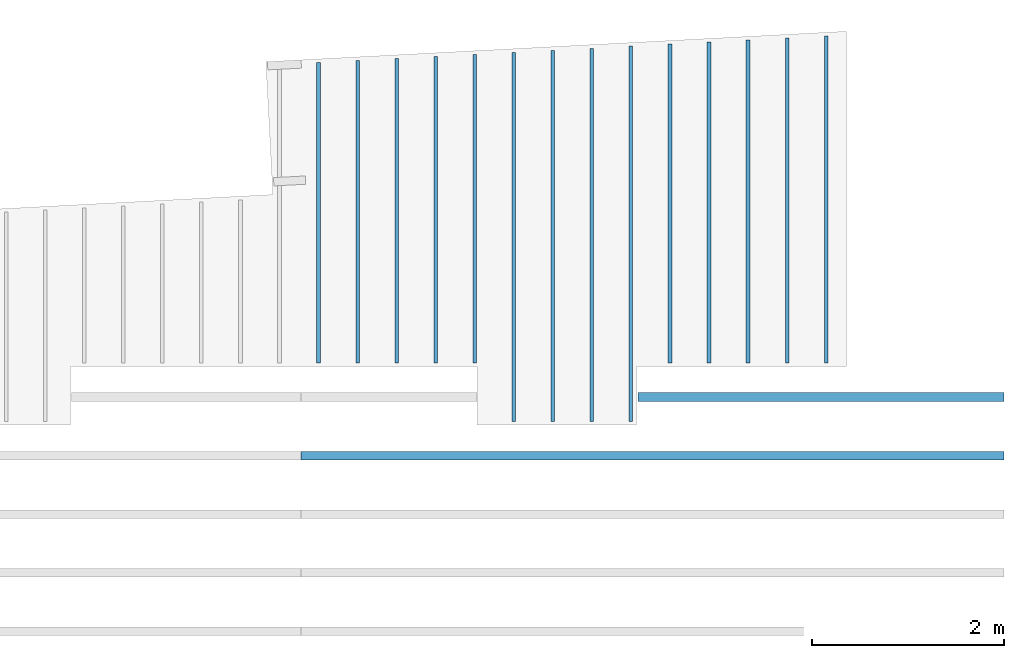
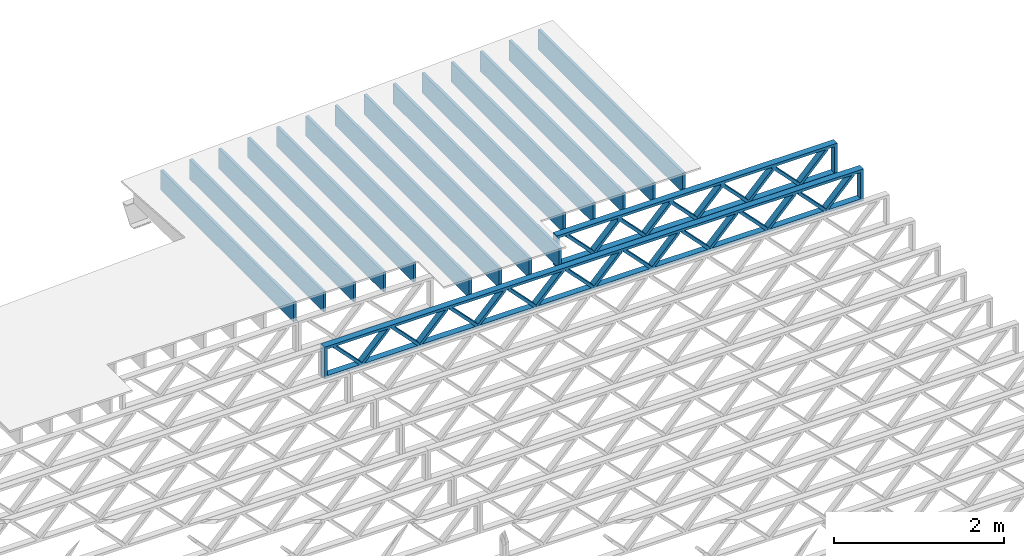
# One storey, part 12 of 13: 16 beams, 2 elements without a shape of their own.
"""IFC4 building model written with IfcOpenShell, lengths in feet."""

from ifc_helpers import new_model, entity, si_unit, converted_unit, derived_unit, direction, frame, frame_2d, origin, origin_2d_with_axis, place, context, subcontext, project, spatial, rectangle, extrude, source, transform, mapped, material, material_profile, profile_set, profile_usage, type_object, type_shapes, element, aggregate, save


model = new_model("IFC4")

# Units and contexts
model_context_1 = context("Model", 3, precision=0.0001, world=origin(), true_north=direction((6.12303176911189e-17, 1.0)))
model_context_2 = context("Model", 3, precision=0.0001, world=origin(), true_north=direction((6.12303176911189e-17, 1.0)))
body_context = subcontext(model_context_2, "Body", "Model", "MODEL_VIEW")
ifc_project = project(units=[converted_unit("LENGTHUNIT", "FOOT", entity("IfcRatioMeasure", 0.3048), si_unit("LENGTHUNIT", "METRE"), dimensions=[1, 0, 0, 0, 0, 0, 0]), converted_unit("AREAUNIT", "SQUARE FOOT", entity("IfcRatioMeasure", 0.09290304), si_unit("AREAUNIT", "SQUARE_METRE"), dimensions=[2, 0, 0, 0, 0, 0, 0]), converted_unit("VOLUMEUNIT", "CUBIC FOOT", entity("IfcRatioMeasure", 0.028316846592), si_unit("VOLUMEUNIT", "CUBIC_METRE"), dimensions=[3, 0, 0, 0, 0, 0, 0]), converted_unit("PLANEANGLEUNIT", "DEGREE", entity("IfcRatioMeasure", 0.0174532925199433), si_unit("PLANEANGLEUNIT", "RADIAN"), dimensions=[0, 0, 0, 0, 0, 0, 0]), si_unit("MASSUNIT", "GRAM", prefix="KILO"), derived_unit("MASSDENSITYUNIT", [(si_unit("MASSUNIT", "GRAM", prefix="KILO"), 1), (si_unit("LENGTHUNIT", "METRE"), -3)]), derived_unit("MOMENTOFINERTIAUNIT", [(si_unit("LENGTHUNIT", "METRE"), 4)]), si_unit("TIMEUNIT", "SECOND"), si_unit("FREQUENCYUNIT", "HERTZ"), si_unit("THERMODYNAMICTEMPERATUREUNIT", "DEGREE_CELSIUS"), derived_unit("THERMALTRANSMITTANCEUNIT", [(si_unit("MASSUNIT", "GRAM", prefix="KILO"), 1), (si_unit("THERMODYNAMICTEMPERATUREUNIT", "KELVIN"), -1), (si_unit("TIMEUNIT", "SECOND"), -3)]), derived_unit("VOLUMETRICFLOWRATEUNIT", [(si_unit("LENGTHUNIT", "METRE"), 3), (si_unit("TIMEUNIT", "SECOND"), -1)]), si_unit("ELECTRICCURRENTUNIT", "AMPERE"), si_unit("ELECTRICVOLTAGEUNIT", "VOLT"), si_unit("POWERUNIT", "WATT"), si_unit("FORCEUNIT", "NEWTON"), si_unit("ILLUMINANCEUNIT", "LUX"), si_unit("LUMINOUSFLUXUNIT", "LUMEN"), si_unit("LUMINOUSINTENSITYUNIT", "CANDELA"), derived_unit("USERDEFINED", [(si_unit("MASSUNIT", "GRAM", prefix="KILO"), -1), (si_unit("LENGTHUNIT", "METRE"), -2), (si_unit("TIMEUNIT", "SECOND"), 3), (si_unit("LUMINOUSFLUXUNIT", "LUMEN"), 1)]), derived_unit("LINEARVELOCITYUNIT", [(si_unit("LENGTHUNIT", "METRE"), 1), (si_unit("TIMEUNIT", "SECOND"), -1)]), si_unit("PRESSUREUNIT", "PASCAL"), derived_unit("USERDEFINED", [(si_unit("LENGTHUNIT", "METRE"), -2), (si_unit("MASSUNIT", "GRAM", prefix="KILO"), 1), (si_unit("TIMEUNIT", "SECOND"), -2)]), derived_unit("LINEARFORCEUNIT", [(si_unit("MASSUNIT", "GRAM", prefix="KILO"), 1), (si_unit("LENGTHUNIT", "METRE"), 1), (si_unit("TIMEUNIT", "SECOND"), -2), (si_unit("LENGTHUNIT", "METRE"), -1)]), derived_unit("PLANARFORCEUNIT", [(si_unit("MASSUNIT", "GRAM", prefix="KILO"), 1), (si_unit("LENGTHUNIT", "METRE"), 1), (si_unit("TIMEUNIT", "SECOND"), -2), (si_unit("LENGTHUNIT", "METRE"), -2)])], contexts=[model_context_1])

# Site, building, storey
site_placement = place(None, origin())
site = spatial("IfcSite", under=ifc_project, at=site_placement, CompositionType="ELEMENT")
building_placement = place(site_placement, origin())
building = spatial("IfcBuilding", under=site, at=building_placement, CompositionType="ELEMENT")
storey_placement = place(building_placement, frame((0.0, 0.0, 21.46875)))
storey = spatial("IfcBuildingStorey", under=building, at=storey_placement, Name="3RD FLOOR", CompositionType="ELEMENT", Elevation=21.46875)

# Assembly, beam
assembly_1_placement = place(storey_placement, origin())
assembly_1 = element("IfcElementAssembly", 1, at=assembly_1_placement, inside=storey, Name="Structural Beam System:Structural Framing System", ObjectType="Structural Beam System:Structural Framing System", AssemblyPlace="NOTDEFINED", PredefinedType="BEAM_GRID")
ifc_material_1 = material(Name="WOOD TRUSS", Category="Materials")
ifc_material_profile_1 = material_profile(ifc_material_1, rectangle(XDim=1.73473973950632, YDim=0.125, at=frame_2d((-1.11022302462516e-16, 8.32667268468867e-17), x_axis=(1.0, 0.0))))
ifc_material_profile_2 = material_profile(ifc_material_1, rectangle(XDim=1.73473973950633, YDim=0.125, at=frame_2d((-1.11022302462516e-16, 8.32667268468867e-17), x_axis=(1.0, 0.0))))
ifc_material_profile_3 = material_profile(ifc_material_1, rectangle(XDim=1.73473973950632, YDim=0.125, at=frame_2d((-5.55111512312578e-17, 1.38777878078145e-16), x_axis=(1.0, 0.0))))
ifc_material_profile_4 = material_profile(ifc_material_1, rectangle(XDim=1.73473973950633, YDim=0.125, at=frame_2d((-1.11022302462516e-16, 8.32667268468867e-17), x_axis=(1.0, 0.0))))
ifc_material_profile_5 = material_profile(ifc_material_1, rectangle(XDim=1.73473973950632, YDim=0.125, at=frame_2d((-1.11022302462516e-16, 8.32667268468867e-17), x_axis=(1.0, 0.0))))
ifc_material_profile_6 = material_profile(ifc_material_1, rectangle(XDim=1.73473973950633, YDim=0.125, at=frame_2d((-2.77555756156289e-16, 3.05311331771918e-16), x_axis=(1.0, 0.0))))
ifc_material_profile_7 = material_profile(ifc_material_1, rectangle(XDim=1.73473973950632, YDim=0.124999999999999, at=frame_2d((-3.88578058618805e-16, -2.4980018054066e-16), x_axis=(1.0, 0.0))))
ifc_material_profile_8 = material_profile(ifc_material_1, rectangle(XDim=1.73473973950633, YDim=0.125, at=frame_2d((2.77555756156289e-16, -3.05311331771918e-16), x_axis=(1.0, 0.0))))
ifc_material_profile_9 = material_profile(ifc_material_1, rectangle(XDim=1.73473973950632, YDim=0.124999999999999, at=frame_2d((-1.11022302462516e-16, 8.32667268468867e-17), x_axis=(1.0, 0.0))))
ifc_material_profile_10 = material_profile(ifc_material_1, rectangle(XDim=1.73473973950633, YDim=0.125, at=origin_2d_with_axis()))
ifc_material_profile_11 = material_profile(ifc_material_1, rectangle(XDim=0.124999999999982, YDim=0.291666666666668, at=origin_2d_with_axis()))
ifc_material_profile_12 = material_profile(ifc_material_1, rectangle(XDim=0.124999999999932, YDim=0.291666666666664, at=origin_2d_with_axis()))
ifc_material_profile_13 = material_profile(ifc_material_1, rectangle(XDim=1.25000000000002, YDim=0.29166666666667, at=origin_2d_with_axis()))
ifc_material_profile_14 = material_profile(ifc_material_1, rectangle(XDim=1.25000000000004, YDim=0.291666666666667, at=origin_2d_with_axis()))
ifc_profile_set_1 = profile_set([ifc_material_profile_1, ifc_material_profile_2, ifc_material_profile_3, ifc_material_profile_4, ifc_material_profile_5, ifc_material_profile_6, ifc_material_profile_7, ifc_material_profile_8, ifc_material_profile_9, ifc_material_profile_10, ifc_material_profile_11, ifc_material_profile_12, ifc_material_profile_13, ifc_material_profile_14])
ifc_profile_usage_1 = profile_usage(ifc_profile_set_1, cardinal=8)
beam_type_1 = type_object("IfcBeamType", PredefinedType="BEAM", material=ifc_profile_set_1)
shared_shape_1 = source(origin(), body_context, "Body", "SweptSolid", [
    extrude(rectangle(XDim=1.73473973950632, YDim=0.125, at=frame_2d((-1.11022302462516e-16, 8.32667268468867e-17), x_axis=(1.0, 0.0))), frame((2.91681155651982, -0.145833333333334, 0.0), z_axis=(0.0, 1.0, 0.0), x_axis=(0.693383046997606, 0.0, 0.720569184836762)), (0.0, 0.0, 1.0), 0.291666666666667),
    extrude(rectangle(XDim=1.73473973950633, YDim=0.125, at=frame_2d((-1.11022302462516e-16, 8.32667268468867e-17), x_axis=(1.0, 0.0))), frame((1.66652568284655, -0.145833333333334, 0.0), z_axis=(0.0, 1.0, 0.0), x_axis=(0.69338304699761, 0.0, -0.720569184836758)), (0.0, 0.0, 1.0), 0.291666666666667),
    extrude(rectangle(XDim=1.73473973950632, YDim=0.125, at=frame_2d((-5.55111512312578e-17, 1.38777878078145e-16), x_axis=(1.0, 0.0))), frame((0.625142936836964, -0.145833333333334, 0.0), z_axis=(0.0, 1.0, 0.0), x_axis=(0.693383046997606, 0.0, 0.720569184836762)), (0.0, 0.0, 1.0), 0.291666666666667),
    extrude(rectangle(XDim=1.73473973950633, YDim=0.125, at=frame_2d((-1.11022302462516e-16, 8.32667268468867e-17), x_axis=(1.0, 0.0))), frame((-0.625142936836307, -0.145833333333334, 0.0), z_axis=(0.0, 1.0, 0.0), x_axis=(0.69338304699761, 0.0, -0.720569184836758)), (0.0, 0.0, 1.0), 0.291666666666667),
    extrude(rectangle(XDim=1.73473973950632, YDim=0.125, at=frame_2d((-1.11022302462516e-16, 8.32667268468867e-17), x_axis=(1.0, 0.0))), frame((-1.66652568284589, -0.145833333333334, 0.0), z_axis=(0.0, 1.0, 0.0), x_axis=(0.693383046997606, 0.0, 0.720569184836762)), (0.0, 0.0, 1.0), 0.291666666666667),
    extrude(rectangle(XDim=1.73473973950633, YDim=0.125, at=frame_2d((-2.77555756156289e-16, 3.05311331771918e-16), x_axis=(1.0, 0.0))), frame((-2.91681155651916, -0.145833333333334, 0.0), z_axis=(0.0, 1.0, 0.0), x_axis=(0.69338304699761, 0.0, -0.720569184836758)), (0.0, 0.0, 1.0), 0.291666666666667),
    extrude(rectangle(XDim=1.73473973950632, YDim=0.124999999999999, at=frame_2d((-3.88578058618805e-16, -2.4980018054066e-16), x_axis=(1.0, 0.0))), frame((5.20848017620267, -0.145833333333334, 0.0), z_axis=(0.0, 1.0, 0.0), x_axis=(0.693383046997607, 0.0, 0.720569184836761)), (0.0, 0.0, 1.0), 0.291666666666666),
    extrude(rectangle(XDim=1.73473973950633, YDim=0.125, at=frame_2d((2.77555756156289e-16, -3.05311331771918e-16), x_axis=(1.0, 0.0))), frame((3.9581943025294, -0.145833333333334, 0.0), z_axis=(0.0, 1.0, 0.0), x_axis=(0.69338304699761, 0.0, -0.720569184836758)), (0.0, 0.0, 1.0), 0.291666666666666),
    extrude(rectangle(XDim=1.73473973950632, YDim=0.124999999999999, at=frame_2d((-1.11022302462516e-16, 8.32667268468867e-17), x_axis=(1.0, 0.0))), frame((-3.95819430252874, -0.145833333333334, 0.0), z_axis=(0.0, 1.0, 0.0), x_axis=(0.693383046997606, 0.0, 0.720569184836762)), (0.0, 0.0, 1.0), 0.291666666666667),
    extrude(rectangle(XDim=1.73473973950633, YDim=0.125, at=origin_2d_with_axis()), frame((-5.20848017620202, -0.145833333333334, 0.0), z_axis=(0.0, 1.0, 0.0), x_axis=(0.69338304699761, 0.0, -0.720569184836758)), (0.0, 0.0, 1.0), 0.291666666666666),
    extrude(rectangle(XDim=0.124999999999982, YDim=0.291666666666668, at=origin_2d_with_axis()), frame((-6.25000390603229, 0.0, 0.687500000000054), z_axis=(1.0, 0.0, 0.0), x_axis=(0.0, 0.0, -1.0)), (0.0, 0.0, 1.0), 12.5000078120646),
    extrude(rectangle(XDim=0.124999999999932, YDim=0.291666666666664, at=origin_2d_with_axis()), frame((-6.25000390603208, 0.0, -0.687499999999984), z_axis=(1.0, 0.0, 0.0), x_axis=(0.0, 0.0, -1.0)), (0.0, 0.0, 1.0), 12.5000078120644),
    extrude(rectangle(XDim=1.25000000000002, YDim=0.29166666666667, at=origin_2d_with_axis()), frame((6.12500390603227, 0.0, 0.0), z_axis=(1.0, 0.0, 0.0), x_axis=(0.0, 0.0, -1.0)), (0.0, 0.0, 1.0), 0.12500000000002),
    extrude(rectangle(XDim=1.25000000000004, YDim=0.291666666666667, at=origin_2d_with_axis()), frame((-6.25000390603229, 0.0, 0.0), z_axis=(1.0, 0.0, 0.0), x_axis=(0.0, 0.0, -1.0)), (0.0, 0.0, 1.0), 0.125000000000023),
])
type_shapes(beam_type_1, [shared_shape_1])
beam_1_placement = place(assembly_1_placement, frame((-146.654823274369, 957.861934882651, -0.947916666657861), z_axis=(0.0, 0.0, 1.0), x_axis=(-1.0, 0.0, 0.0)))
beam_1 = element("IfcBeam", 2, at=beam_1_placement, type_object=beam_type_1, material=ifc_profile_usage_1, PredefinedType="BEAM", context=body_context, shape_type="MappedRepresentation", body=[
    mapped(shared_shape_1, transform((0.0, 0.0, 0.0), scale=1.0)),
])

# Assembly, beams
assembly_2_placement = place(storey_placement, origin())
assembly_2 = element("IfcElementAssembly", 3, at=assembly_2_placement, inside=storey, Name="Structural Beam System:Structural Framing System", ObjectType="Structural Beam System:Structural Framing System", AssemblyPlace="NOTDEFINED", PredefinedType="BEAM_GRID")
ifc_material_2 = material(Category="Materials")
ifc_material_profile_15 = material_profile(ifc_material_2, rectangle(XDim=0.9375, YDim=0.125000000000011, at=origin_2d_with_axis()))
ifc_profile_set_2 = profile_set([ifc_material_profile_15])
ifc_profile_usage_2 = profile_usage(ifc_profile_set_2, cardinal=8)
beam_type_2 = type_object("IfcBeamType", PredefinedType="BEAM", material=ifc_profile_set_2)
shared_shape_2 = source(origin(), body_context, "Body", "SweptSolid", [
    extrude(rectangle(XDim=0.9375, YDim=0.125000000000011, at=origin_2d_with_axis()), frame((-5.54551465436788, 0.0, 0.0), z_axis=(1.0, 0.0, 0.0), x_axis=(0.0, 0.0, -1.0)), (0.0, 0.0, 1.0), 11.0910293087358),
])
type_shapes(beam_type_2, [shared_shape_2])
beam_2_placement = place(assembly_2_placement, frame((-147.810956052701, 964.574113608269, -0.729166666666714), z_axis=(0.0, 0.0, 1.0), x_axis=(0.0, 1.0, 0.0)))
beam_2 = element("IfcBeam", 4, at=beam_2_placement, type_object=beam_type_2, material=ifc_profile_usage_2, PredefinedType="BEAM", context=body_context, shape_type="MappedRepresentation", body=[
    mapped(shared_shape_2, transform((0.0, 0.0, 0.0), scale=1.0)),
])
ifc_profile_usage_3 = profile_usage(ifc_profile_set_2, cardinal=8)
beam_type_3 = type_object("IfcBeamType", PredefinedType="BEAM", material=ifc_profile_set_2)
shared_shape_3 = source(origin(), body_context, "Body", "SweptSolid", [
    extrude(rectangle(XDim=0.9375, YDim=0.125000000000011, at=origin_2d_with_axis()), frame((-5.44069959830534, 0.0, 0.0), z_axis=(1.0, 0.0, 0.0), x_axis=(0.0, 0.0, -1.0)), (0.0, 0.0, 1.0), 10.8813991966107),
])
type_shapes(beam_type_3, [shared_shape_3])
beam_3_placement = place(assembly_2_placement, frame((-151.810956052701, 964.469297547199, -0.729166666666714), z_axis=(0.0, 0.0, 1.0), x_axis=(0.0, 1.0, 0.0)))
beam_3 = element("IfcBeam", 5, at=beam_3_placement, type_object=beam_type_3, material=ifc_profile_usage_3, PredefinedType="BEAM", context=body_context, shape_type="MappedRepresentation", body=[
    mapped(shared_shape_3, transform((0.0, 0.0, 0.0), scale=1.0)),
])
ifc_profile_usage_4 = profile_usage(ifc_profile_set_2, cardinal=8)
beam_type_4 = type_object("IfcBeamType", PredefinedType="BEAM", material=ifc_profile_set_2)
shared_shape_4 = source(origin(), body_context, "Body", "SweptSolid", [
    extrude(rectangle(XDim=0.9375, YDim=0.125000000000011, at=origin_2d_with_axis()), frame((-6.40576098092373, 0.0, 0.0), z_axis=(1.0, 0.0, 0.0), x_axis=(0.0, 0.0, -1.0)), (0.0, 0.0, 1.0), 12.8115219618475),
])
type_shapes(beam_type_4, [shared_shape_4])
beam_4_placement = place(assembly_2_placement, frame((-153.144289386034, 963.434359125537, -0.729166666666714), z_axis=(0.0, 0.0, 1.0), x_axis=(0.0, 1.0, 0.0)))
beam_4 = element("IfcBeam", 6, at=beam_4_placement, type_object=beam_type_4, material=ifc_profile_usage_4, PredefinedType="BEAM", context=body_context, shape_type="MappedRepresentation", body=[
    mapped(shared_shape_4, transform((0.0, 0.0, 0.0), scale=1.0)),
])
ifc_profile_usage_5 = profile_usage(ifc_profile_set_2, cardinal=8)
beam_type_5 = type_object("IfcBeamType", PredefinedType="BEAM", material=ifc_profile_set_2)
shared_shape_5 = source(origin(), body_context, "Body", "SweptSolid", [
    extrude(rectangle(XDim=0.9375, YDim=0.125000000000011, at=origin_2d_with_axis()), frame((-6.3708224614017, 0.0, 0.0), z_axis=(1.0, 0.0, 0.0), x_axis=(0.0, 0.0, -1.0)), (0.0, 0.0, 1.0), 12.7416449228034),
])
type_shapes(beam_type_5, [shared_shape_5])
beam_5_placement = place(assembly_2_placement, frame((-154.477622719368, 963.399420606015, -0.729166666666714), z_axis=(0.0, 0.0, 1.0), x_axis=(0.0, 1.0, 0.0)))
beam_5 = element("IfcBeam", 7, at=beam_5_placement, type_object=beam_type_5, material=ifc_profile_usage_5, PredefinedType="BEAM", context=body_context, shape_type="MappedRepresentation", body=[
    mapped(shared_shape_5, transform((0.0, 0.0, 0.0), scale=1.0)),
])
ifc_profile_usage_6 = profile_usage(ifc_profile_set_2, cardinal=8)
beam_type_6 = type_object("IfcBeamType", PredefinedType="BEAM", material=ifc_profile_set_2)
shared_shape_6 = source(origin(), body_context, "Body", "SweptSolid", [
    extrude(rectangle(XDim=0.9375, YDim=0.125000000000011, at=origin_2d_with_axis()), frame((-6.33588394187967, 0.0, 0.0), z_axis=(1.0, 0.0, 0.0), x_axis=(0.0, 0.0, -1.0)), (0.0, 0.0, 1.0), 12.6717678837593),
])
type_shapes(beam_type_6, [shared_shape_6])
beam_6_placement = place(assembly_2_placement, frame((-155.810956052701, 963.364482086493, -0.729166666666714), z_axis=(0.0, 0.0, 1.0), x_axis=(0.0, 1.0, 0.0)))
beam_6 = element("IfcBeam", 8, at=beam_6_placement, type_object=beam_type_6, material=ifc_profile_usage_6, PredefinedType="BEAM", context=body_context, shape_type="MappedRepresentation", body=[
    mapped(shared_shape_6, transform((0.0, 0.0, 0.0), scale=1.0)),
])
ifc_profile_usage_7 = profile_usage(ifc_profile_set_2, cardinal=8)
beam_type_7 = type_object("IfcBeamType", PredefinedType="BEAM", material=ifc_profile_set_2)
shared_shape_7 = source(origin(), body_context, "Body", "SweptSolid", [
    extrude(rectangle(XDim=0.9375, YDim=0.125000000000011, at=origin_2d_with_axis()), frame((-5.19612881309462, 0.0, 0.0), z_axis=(1.0, 0.0, 0.0), x_axis=(0.0, 0.0, -1.0)), (0.0, 0.0, 1.0), 10.3922576261892),
])
type_shapes(beam_type_7, [shared_shape_7])
beam_7_placement = place(assembly_2_placement, frame((-161.144289386034, 964.224729059102, -0.729166666666714), z_axis=(0.0, 0.0, 1.0), x_axis=(0.0, 1.0, 0.0)))
beam_7 = element("IfcBeam", 9, at=beam_7_placement, type_object=beam_type_7, material=ifc_profile_usage_7, PredefinedType="BEAM", context=body_context, shape_type="MappedRepresentation", body=[
    mapped(shared_shape_7, transform((0.0, 0.0, 0.0), scale=1.0)),
])
ifc_profile_usage_8 = profile_usage(ifc_profile_set_2, cardinal=8)
beam_type_8 = type_object("IfcBeamType", PredefinedType="BEAM", material=ifc_profile_set_2)
shared_shape_8 = source(origin(), body_context, "Body", "SweptSolid", [
    extrude(rectangle(XDim=0.9375, YDim=0.125000000000011, at=origin_2d_with_axis()), frame((-5.16119046107383, 0.0, 0.0), z_axis=(1.0, 0.0, 0.0), x_axis=(0.0, 0.0, -1.0)), (0.0, 0.0, 1.0), 10.3223809221477),
])
type_shapes(beam_type_8, [shared_shape_8])
beam_8_placement = place(assembly_2_placement, frame((-162.477622719368, 964.189790372079, -0.729166666666714), z_axis=(0.0, 0.0, 1.0), x_axis=(0.0, 1.0, 0.0)))
beam_8 = element("IfcBeam", 10, at=beam_8_placement, type_object=beam_type_8, material=ifc_profile_usage_8, PredefinedType="BEAM", context=body_context, shape_type="MappedRepresentation", body=[
    mapped(shared_shape_8, transform((0.0, 0.0, 0.0), scale=1.0)),
])
ifc_profile_usage_9 = profile_usage(ifc_profile_set_2, cardinal=8)
beam_type_9 = type_object("IfcBeamType", PredefinedType="BEAM", material=ifc_profile_set_2)
shared_shape_9 = source(origin(), body_context, "Body", "SweptSolid", [
    extrude(rectangle(XDim=0.9375, YDim=0.125000000000011, at=origin_2d_with_axis()), frame((-5.1262521090531, 0.0, 0.0), z_axis=(1.0, 0.0, 0.0), x_axis=(0.0, 0.0, -1.0)), (0.0, 0.0, 1.0), 10.2525042181062),
])
type_shapes(beam_type_9, [shared_shape_9])
beam_9_placement = place(assembly_2_placement, frame((-163.810956052701, 964.154851685055, -0.729166666666714), z_axis=(0.0, 0.0, 1.0), x_axis=(0.0, 1.0, 0.0)))
beam_9 = element("IfcBeam", 11, at=beam_9_placement, type_object=beam_type_9, material=ifc_profile_usage_9, PredefinedType="BEAM", context=body_context, shape_type="MappedRepresentation", body=[
    mapped(shared_shape_9, transform((0.0, 0.0, 0.0), scale=1.0)),
])
ifc_profile_usage_10 = profile_usage(ifc_profile_set_2, cardinal=8)
beam_type_10 = type_object("IfcBeamType", PredefinedType="BEAM", material=ifc_profile_set_2)
shared_shape_10 = source(origin(), body_context, "Body", "SweptSolid", [
    extrude(rectangle(XDim=0.9375, YDim=0.125000000000011, at=origin_2d_with_axis()), frame((-5.23106716511541, 0.0, 0.0), z_axis=(1.0, 0.0, 0.0), x_axis=(0.0, 0.0, -1.0)), (0.0, 0.0, 1.0), 10.4621343302308),
])
type_shapes(beam_type_10, [shared_shape_10])
beam_10_placement = place(assembly_2_placement, frame((-159.810956052701, 964.259667746125, -0.729166666666714), z_axis=(0.0, 0.0, 1.0), x_axis=(0.0, 1.0, 0.0)))
beam_10 = element("IfcBeam", 12, at=beam_10_placement, type_object=beam_type_10, material=ifc_profile_usage_10, PredefinedType="BEAM", context=body_context, shape_type="MappedRepresentation", body=[
    mapped(shared_shape_10, transform((0.0, 0.0, 0.0), scale=1.0)),
])
ifc_profile_usage_11 = profile_usage(ifc_profile_set_2, cardinal=8)
beam_type_11 = type_object("IfcBeamType", PredefinedType="BEAM", material=ifc_profile_set_2)
shared_shape_11 = source(origin(), body_context, "Body", "SweptSolid", [
    extrude(rectangle(XDim=0.9375, YDim=0.125000000000011, at=origin_2d_with_axis()), frame((-5.26600551713619, 0.0, 0.0), z_axis=(1.0, 0.0, 0.0), x_axis=(0.0, 0.0, -1.0)), (0.0, 0.0, 1.0), 10.5320110342724),
])
type_shapes(beam_type_11, [shared_shape_11])
beam_11_placement = place(assembly_2_placement, frame((-158.477622719368, 964.294606433148, -0.729166666666714), z_axis=(0.0, 0.0, 1.0), x_axis=(0.0, 1.0, 0.0)))
beam_11 = element("IfcBeam", 13, at=beam_11_placement, type_object=beam_type_11, material=ifc_profile_usage_11, PredefinedType="BEAM", context=body_context, shape_type="MappedRepresentation", body=[
    mapped(shared_shape_11, transform((0.0, 0.0, 0.0), scale=1.0)),
])
ifc_profile_usage_12 = profile_usage(ifc_profile_set_2, cardinal=8)
beam_type_12 = type_object("IfcBeamType", PredefinedType="BEAM", material=ifc_profile_set_2)
shared_shape_12 = source(origin(), body_context, "Body", "SweptSolid", [
    extrude(rectangle(XDim=0.9375, YDim=0.125000000000011, at=origin_2d_with_axis()), frame((-6.30094542235764, 0.0, 0.0), z_axis=(1.0, 0.0, 0.0), x_axis=(0.0, 0.0, -1.0)), (0.0, 0.0, 1.0), 12.6018908447153),
])
type_shapes(beam_type_12, [shared_shape_12])
beam_12_placement = place(assembly_2_placement, frame((-157.144289386034, 963.329543566971, -0.729166666666714), z_axis=(0.0, 0.0, 1.0), x_axis=(0.0, 1.0, 0.0)))
beam_12 = element("IfcBeam", 14, at=beam_12_placement, type_object=beam_type_12, material=ifc_profile_usage_12, PredefinedType="BEAM", context=body_context, shape_type="MappedRepresentation", body=[
    mapped(shared_shape_12, transform((0.0, 0.0, 0.0), scale=1.0)),
])
ifc_profile_usage_13 = profile_usage(ifc_profile_set_2, cardinal=8)
beam_type_13 = type_object("IfcBeamType", PredefinedType="BEAM", material=ifc_profile_set_2)
shared_shape_13 = source(origin(), body_context, "Body", "SweptSolid", [
    extrude(rectangle(XDim=0.9375, YDim=0.125000000000011, at=origin_2d_with_axis()), frame((-5.47563795032625, 0.0, 0.0), z_axis=(1.0, 0.0, 0.0), x_axis=(0.0, 0.0, -1.0)), (0.0, 0.0, 1.0), 10.9512759006525),
])
type_shapes(beam_type_13, [shared_shape_13])
beam_13_placement = place(assembly_2_placement, frame((-150.477622719368, 964.504236234223, -0.729166666666714), z_axis=(0.0, 0.0, 1.0), x_axis=(0.0, 1.0, 0.0)))
beam_13 = element("IfcBeam", 15, at=beam_13_placement, type_object=beam_type_13, material=ifc_profile_usage_13, PredefinedType="BEAM", context=body_context, shape_type="MappedRepresentation", body=[
    mapped(shared_shape_13, transform((0.0, 0.0, 0.0), scale=1.0)),
])
ifc_profile_usage_14 = profile_usage(ifc_profile_set_2, cardinal=8)
beam_type_14 = type_object("IfcBeamType", PredefinedType="BEAM", material=ifc_profile_set_2)
shared_shape_14 = source(origin(), body_context, "Body", "SweptSolid", [
    extrude(rectangle(XDim=0.9375, YDim=0.125000000000011, at=origin_2d_with_axis()), frame((-5.51057630234703, 0.0, 0.0), z_axis=(1.0, 0.0, 0.0), x_axis=(0.0, 0.0, -1.0)), (0.0, 0.0, 1.0), 11.0211526046941),
])
type_shapes(beam_type_14, [shared_shape_14])
beam_14_placement = place(assembly_2_placement, frame((-149.144289386034, 964.539174921246, -0.729166666666714), z_axis=(0.0, 0.0, 1.0), x_axis=(0.0, 1.0, 0.0)))
beam_14 = element("IfcBeam", 16, at=beam_14_placement, type_object=beam_type_14, material=ifc_profile_usage_14, PredefinedType="BEAM", context=body_context, shape_type="MappedRepresentation", body=[
    mapped(shared_shape_14, transform((0.0, 0.0, 0.0), scale=1.0)),
])
ifc_profile_usage_15 = profile_usage(ifc_profile_set_2, cardinal=8)
beam_type_15 = type_object("IfcBeamType", PredefinedType="BEAM", material=ifc_profile_set_2)
shared_shape_15 = source(origin(), body_context, "Body", "SweptSolid", [
    extrude(rectangle(XDim=0.9375, YDim=0.125000000000011, at=origin_2d_with_axis()), frame((-5.58045300638878, 0.0, 0.0), z_axis=(1.0, 0.0, 0.0), x_axis=(0.0, 0.0, -1.0)), (0.0, 0.0, 1.0), 11.1609060127776),
])
type_shapes(beam_type_15, [shared_shape_15])
beam_15_placement = place(assembly_2_placement, frame((-146.477622719368, 964.609052295292, -0.729166666666714), z_axis=(0.0, 0.0, 1.0), x_axis=(0.0, 1.0, 0.0)))
beam_15 = element("IfcBeam", 17, at=beam_15_placement, type_object=beam_type_15, material=ifc_profile_usage_15, PredefinedType="BEAM", context=body_context, shape_type="MappedRepresentation", body=[
    mapped(shared_shape_15, transform((0.0, 0.0, 0.0), scale=1.0)),
])
aggregate(assembly_2, [beam_2, beam_3, beam_4, beam_5, beam_6, beam_7, beam_8, beam_9, beam_10, beam_11, beam_12, beam_13, beam_14, beam_15])

# Beam
ifc_profile_usage_16 = profile_usage(ifc_profile_set_1, cardinal=8)
beam_type_16 = type_object("IfcBeamType", PredefinedType="BEAM", material=ifc_profile_set_1)
shared_shape_16 = source(origin(), body_context, "Body", "SweptSolid", [
    extrude(rectangle(XDim=1.73473973950632, YDim=0.124999999999999, at=frame_2d((5.55111512312578e-16, 7.21644966006352e-16), x_axis=(1.0, 0.0))), frame((8.37514585578398, -0.145833333333334, 0.0), z_axis=(0.0, 1.0, 0.0), x_axis=(0.693383046997606, 0.0, 0.720569184836762)), (0.0, 0.0, 1.0), 0.291666666666667),
    extrude(rectangle(XDim=1.73473973950633, YDim=0.125, at=origin_2d_with_axis()), frame((7.12485998211071, -0.145833333333334, 0.0), z_axis=(0.0, 1.0, 0.0), x_axis=(0.69338304699761, 0.0, -0.720569184836758)), (0.0, 0.0, 1.0), 0.291666666666666),
    extrude(rectangle(XDim=1.73473973950632, YDim=0.124999999999999, at=frame_2d((-1.11022302462516e-16, 8.32667268468867e-17), x_axis=(1.0, 0.0))), frame((5.79181154946831, -0.145833333333334, 0.0), z_axis=(0.0, 1.0, 0.0), x_axis=(0.693383046997606, 0.0, 0.720569184836762)), (0.0, 0.0, 1.0), 0.291666666666667),
    extrude(rectangle(XDim=1.73473973950633, YDim=0.125, at=origin_2d_with_axis()), frame((4.54152567579504, -0.145833333333334, 0.0), z_axis=(0.0, 1.0, 0.0), x_axis=(0.69338304699761, 0.0, -0.720569184836758)), (0.0, 0.0, 1.0), 0.291666666666666),
    extrude(rectangle(XDim=1.73473973950632, YDim=0.125, at=frame_2d((2.22044604925031e-16, 3.88578058618805e-16), x_axis=(1.0, 0.0))), frame((3.20847724315264, -0.145833333333334, 0.0), z_axis=(0.0, 1.0, 0.0), x_axis=(0.693383046997606, 0.0, 0.720569184836762)), (0.0, 0.0, 1.0), 0.291666666666667),
    extrude(rectangle(XDim=1.73473973950633, YDim=0.125, at=frame_2d((-1.11022302462516e-16, 8.32667268468867e-17), x_axis=(1.0, 0.0))), frame((1.95819136947937, -0.145833333333334, 0.0), z_axis=(0.0, 1.0, 0.0), x_axis=(0.69338304699761, 0.0, -0.720569184836758)), (0.0, 0.0, 1.0), 0.291666666666667),
    extrude(rectangle(XDim=1.73473973950632, YDim=0.125, at=frame_2d((-5.55111512312578e-17, 1.38777878078145e-16), x_axis=(1.0, 0.0))), frame((0.625142936836964, -0.145833333333334, 0.0), z_axis=(0.0, 1.0, 0.0), x_axis=(0.693383046997606, 0.0, 0.720569184836762)), (0.0, 0.0, 1.0), 0.291666666666667),
    extrude(rectangle(XDim=1.73473973950633, YDim=0.125, at=frame_2d((-1.11022302462516e-16, 8.32667268468867e-17), x_axis=(1.0, 0.0))), frame((-0.625142936836306, -0.145833333333334, 0.0), z_axis=(0.0, 1.0, 0.0), x_axis=(0.69338304699761, 0.0, -0.720569184836758)), (0.0, 0.0, 1.0), 0.291666666666667),
    extrude(rectangle(XDim=1.73473973950632, YDim=0.125, at=frame_2d((-1.11022302462516e-16, 8.32667268468867e-17), x_axis=(1.0, 0.0))), frame((-1.95819136947871, -0.145833333333334, 0.0), z_axis=(0.0, 1.0, 0.0), x_axis=(0.693383046997606, 0.0, 0.720569184836762)), (0.0, 0.0, 1.0), 0.291666666666667),
    extrude(rectangle(XDim=1.73473973950633, YDim=0.125, at=origin_2d_with_axis()), frame((-3.20847724315198, -0.145833333333334, 0.0), z_axis=(0.0, 1.0, 0.0), x_axis=(0.69338304699761, 0.0, -0.720569184836758)), (0.0, 0.0, 1.0), 0.291666666666667),
    extrude(rectangle(XDim=1.73473973950632, YDim=0.124999999999999, at=frame_2d((-1.11022302462516e-16, 8.32667268468867e-17), x_axis=(1.0, 0.0))), frame((-4.54152567579438, -0.145833333333334, 0.0), z_axis=(0.0, 1.0, 0.0), x_axis=(0.693383046997606, 0.0, 0.720569184836762)), (0.0, 0.0, 1.0), 0.291666666666667),
    extrude(rectangle(XDim=1.73473973950633, YDim=0.125, at=origin_2d_with_axis()), frame((-5.79181154946765, -0.145833333333334, 0.0), z_axis=(0.0, 1.0, 0.0), x_axis=(0.69338304699761, 0.0, -0.720569184836758)), (0.0, 0.0, 1.0), 0.291666666666666),
    extrude(rectangle(XDim=1.73473973950632, YDim=0.124999999999999, at=frame_2d((-1.11022302462516e-16, 8.32667268468867e-17), x_axis=(1.0, 0.0))), frame((-7.12485998211005, -0.145833333333334, 0.0), z_axis=(0.0, 1.0, 0.0), x_axis=(0.693383046997606, 0.0, 0.720569184836762)), (0.0, 0.0, 1.0), 0.291666666666667),
    extrude(rectangle(XDim=1.73473973950633, YDim=0.125, at=frame_2d((-2.77555756156289e-16, 3.05311331771918e-16), x_axis=(1.0, 0.0))), frame((-8.37514585578332, -0.145833333333334, 0.0), z_axis=(0.0, 1.0, 0.0), x_axis=(0.69338304699761, 0.0, -0.720569184836758)), (0.0, 0.0, 1.0), 0.291666666666666),
    extrude(rectangle(XDim=1.73473973950632, YDim=0.125, at=frame_2d((-7.21644966006352e-16, -5.55111512312578e-16), x_axis=(1.0, 0.0))), frame((10.9584801620997, -0.145833333333334, 0.0), z_axis=(0.0, 1.0, 0.0), x_axis=(0.693383046997606, 0.0, 0.720569184836762)), (0.0, 0.0, 1.0), 0.291666666666667),
    extrude(rectangle(XDim=1.73473973950633, YDim=0.125, at=origin_2d_with_axis()), frame((9.70819428842638, -0.145833333333334, 0.0), z_axis=(0.0, 1.0, 0.0), x_axis=(0.69338304699761, 0.0, -0.720569184836758)), (0.0, 0.0, 1.0), 0.291666666666666),
    extrude(rectangle(XDim=1.73473973950632, YDim=0.125, at=frame_2d((-5.55111512312578e-17, 8.32667268468867e-17), x_axis=(1.0, 0.0))), frame((-9.70819428842572, -0.145833333333334, 0.0), z_axis=(0.0, 1.0, 0.0), x_axis=(0.693383046997606, 0.0, 0.720569184836762)), (0.0, 0.0, 1.0), 0.291666666666667),
    extrude(rectangle(XDim=1.73473973950633, YDim=0.125, at=origin_2d_with_axis()), frame((-10.958480162099, -0.145833333333334, 0.0), z_axis=(0.0, 1.0, 0.0), x_axis=(0.69338304699761, 0.0, -0.720569184836758)), (0.0, 0.0, 1.0), 0.291666666666666),
    extrude(rectangle(XDim=0.124999999999982, YDim=0.291666666666668, at=origin_2d_with_axis()), frame((-12.0000038919293, 0.0, 0.687500000000054), z_axis=(1.0, 0.0, 0.0), x_axis=(0.0, 0.0, -1.0)), (0.0, 0.0, 1.0), 24.0000077838585),
    extrude(rectangle(XDim=0.124999999999932, YDim=0.291666666666664, at=origin_2d_with_axis()), frame((-12.0000038919291, 0.0, -0.687499999999984), z_axis=(1.0, 0.0, 0.0), x_axis=(0.0, 0.0, -1.0)), (0.0, 0.0, 1.0), 24.0000077838583),
    extrude(rectangle(XDim=1.25000000000002, YDim=0.29166666666667, at=origin_2d_with_axis()), frame((11.8750038919292, 0.0, 0.0), z_axis=(1.0, 0.0, 0.0), x_axis=(0.0, 0.0, -1.0)), (0.0, 0.0, 1.0), 0.12500000000002),
    extrude(rectangle(XDim=1.25000000000004, YDim=0.291666666666667, at=origin_2d_with_axis()), frame((-12.0000038919293, 0.0, 0.0), z_axis=(1.0, 0.0, 0.0), x_axis=(0.0, 0.0, -1.0)), (0.0, 0.0, 1.0), 0.125000000000023),
])
type_shapes(beam_type_16, [shared_shape_16])
beam_16_placement = place(assembly_1_placement, frame((-152.404823260266, 955.861934882651, -0.947916666657864), z_axis=(0.0, 0.0, 1.0), x_axis=(-1.0, 0.0, 0.0)))
beam_16 = element("IfcBeam", 18, at=beam_16_placement, type_object=beam_type_16, material=ifc_profile_usage_16, PredefinedType="BEAM", context=body_context, shape_type="MappedRepresentation", body=[
    mapped(shared_shape_16, transform((0.0, 0.0, 0.0), scale=1.0)),
])

aggregate(assembly_1, [beam_1, beam_16])

save(model, "model.ifc")
